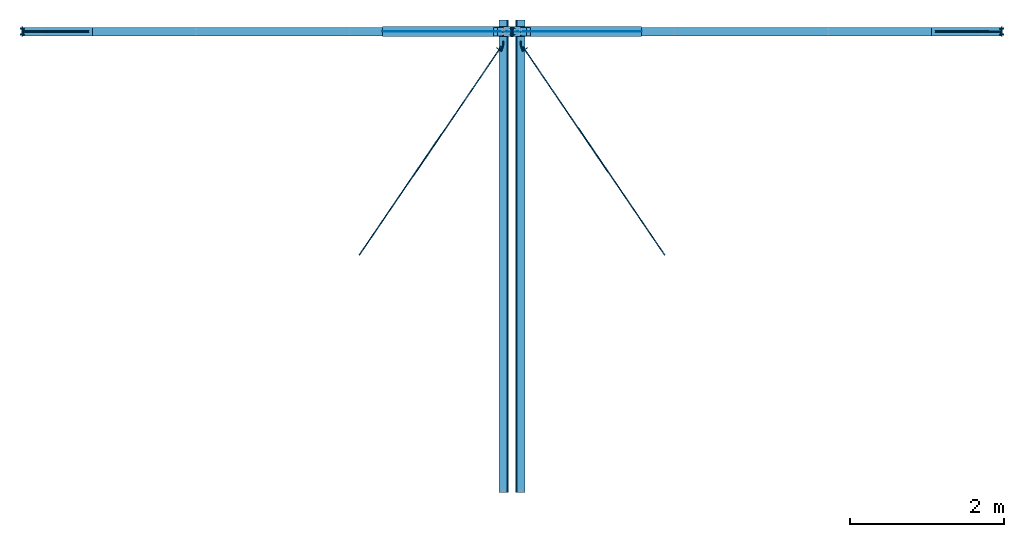
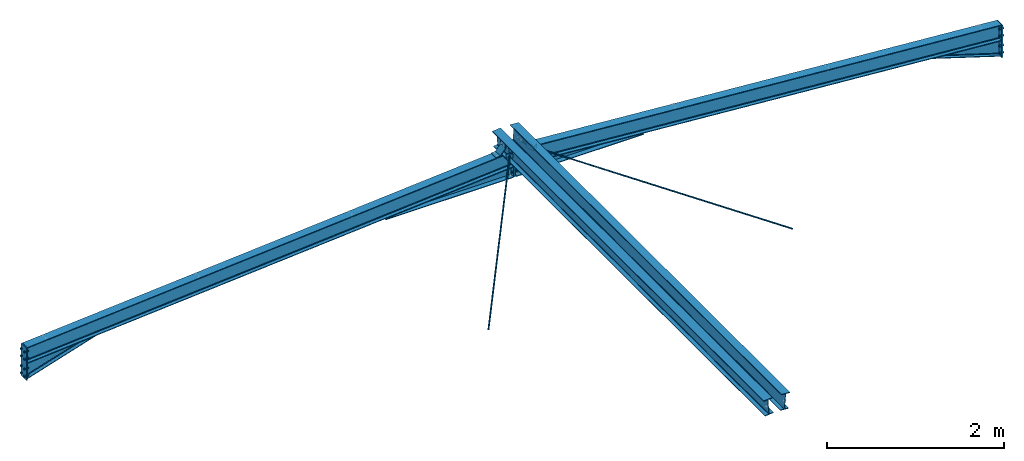
# One storey, part 1 of 3: 10 beams, 10 discrete accessories, 3 mechanical fasteners, 10 elements without a shape of their own.
"""IFC2X3 building model written with IfcOpenShell, lengths in millimetres."""

from ifc_helpers import new_model, si_unit, frame, origin_with_axes, origin_2d_with_axis, place, context, subcontext, project, spatial, polyline, circle, i_section, outline, extrude, clip, halfspace, faceted_brep, source, transform, mapped, material, type_object, element, aggregate, save


model = new_model("IFC2X3")

# Units and contexts
model_context = context("Model", 3, precision=1e-05, world=origin_with_axes())
body_context = subcontext(model_context, "Body", "Model", "MODEL_VIEW")
ifc_project = project(units=[si_unit("LENGTHUNIT", "METRE", prefix="MILLI"), si_unit("AREAUNIT", "SQUARE_METRE"), si_unit("VOLUMEUNIT", "CUBIC_METRE"), si_unit("MASSUNIT", "GRAM", prefix="KILO"), si_unit("TIMEUNIT", "SECOND"), si_unit("PLANEANGLEUNIT", "RADIAN"), si_unit("SOLIDANGLEUNIT", "STERADIAN"), si_unit("THERMODYNAMICTEMPERATUREUNIT", "DEGREE_CELSIUS"), si_unit("LUMINOUSINTENSITYUNIT", "LUMEN")], contexts=[model_context])

# Site, building, storey
site_placement = place(None, origin_with_axes())
site = spatial("IfcSite", under=ifc_project, at=site_placement, CompositionType="ELEMENT")
building_placement = place(site_placement, origin_with_axes())
building = spatial("IfcBuilding", under=site, at=building_placement, Name="Undefined", CompositionType="ELEMENT")
storey_placement = place(building_placement, origin_with_axes())
storey = spatial("IfcBuildingStorey", under=building, at=storey_placement, Name="Undefined", CompositionType="ELEMENT", Elevation=0.0)

# Assembly, beam
assembly_1_placement = place(storey_placement, origin_with_axes())
assembly_1 = element("IfcElementAssembly", 1, at=assembly_1_placement, inside=storey, Name="Steel Assembly", AssemblyPlace="NOTDEFINED", PredefinedType="RIGID_FRAME")
ifc_material_1 = material(Name="STEEL/S235JR")
beam_type_1 = type_object("IfcBeamType", PredefinedType="NOTDEFINED")
beam_1_placement = place(assembly_1_placement, frame((6257.16427529158, 24000.0, 5085.33214623635), z_axis=(0.0, 1.0, 0.0), x_axis=(0.997054485489816, 0.0, 0.0766964990376847)))
beam_1 = element("IfcBeam", 2, at=beam_1_placement, type_object=beam_type_1, material=ifc_material_1, context=body_context, shape_type="Brep", body=[
    faceted_brep([(-1.82262738235295e-09, -4.0, -55.0), (-1.82262738235295e-09, -4.0, 55.0), (1.82262738235295e-09, 4.0, 55.0), (1.82262738235295e-09, 4.0, -55.0), (59.9999997622708, 3.9999999726524, 55.0), (59.9999997622708, 3.9999999726524, -55.0), (56.6862911382423, -4.00000002583693, -55.0), (56.6862911382423, -4.00000002583693, 55.0), (139.999996300323, -76.0000007831222, 55.0), (139.999996300323, -76.0000007831222, -55.0), (131.999996203882, -79.3137090621321, -55.0), (131.999996203882, -79.3137090621321, 55.0), (139.999994554104, -135.999996851768, 55.0), (139.999994554104, -135.999996851768, -55.0), (131.999994554104, -135.999996618938, 55.0), (131.999994554104, -135.999996618938, -55.0)], [[[0, 1, 2, 3]], [[3, 2, 4, 5]], [[1, 0, 6, 7]], [[5, 4, 8, 9]], [[7, 6, 10, 11]], [[9, 8, 12, 13]], [[8, 4, 2, 1, 7, 11, 14, 12]], [[11, 10, 15, 14]], [[10, 6, 0, 3, 5, 9, 13, 15]], [[14, 15, 13, 12]]]),
])
aggregate(assembly_1, [beam_1])

assembly_2_placement = place(storey_placement, origin_with_axes())
assembly_2 = element("IfcElementAssembly", 3, at=assembly_2_placement, inside=storey, Name="Steel Assembly", AssemblyPlace="NOTDEFINED", PredefinedType="RIGID_FRAME")
beam_2_placement = place(assembly_2_placement, frame((6742.83572470515, 24000.0, 5085.33214622012), z_axis=(0.0, -1.0, 0.0), x_axis=(-0.997054485489818, 0.0, 0.0766964990376708)))
beam_2 = element("IfcBeam", 4, at=beam_2_placement, type_object=beam_type_1, material=ifc_material_1, context=body_context, shape_type="Brep", body=[
    faceted_brep([(-1.82262738235295e-09, -4.0, -55.0), (-1.82262738235295e-09, -4.0, 55.0), (1.82262738235295e-09, 4.0, 55.0), (1.82262738235295e-09, 4.0, -55.0), (59.9999997622708, 3.9999999726524, 55.0), (59.9999997622708, 3.9999999726524, -55.0), (56.6862911382423, -4.00000002583693, -55.0), (56.6862911382423, -4.00000002583693, 55.0), (139.999996300323, -76.0000007831222, 55.0), (139.999996300323, -76.0000007831222, -55.0), (131.999996203882, -79.3137090621321, -55.0), (131.999996203882, -79.3137090621321, 55.0), (139.999994554104, -135.999996851768, 55.0), (139.999994554104, -135.999996851768, -55.0), (131.999994554104, -135.999996618938, 55.0), (131.999994554104, -135.999996618938, -55.0)], [[[0, 1, 2, 3]], [[3, 2, 4, 5]], [[1, 0, 6, 7]], [[5, 4, 8, 9]], [[7, 6, 10, 11]], [[9, 8, 12, 13]], [[8, 4, 2, 1, 7, 11, 14, 12]], [[11, 10, 15, 14]], [[10, 6, 0, 3, 5, 9, 13, 15]], [[14, 15, 13, 12]]]),
])
aggregate(assembly_2, [beam_2])

assembly_3_placement = place(storey_placement, origin_with_axes())
assembly_3 = element("IfcElementAssembly", 5, at=assembly_3_placement, inside=storey, Name="Steel Assembly", AssemblyPlace="NOTDEFINED", PredefinedType="RIGID_FRAME")
beam_type_2 = type_object("IfcBeamType", Name="D14", PredefinedType="NOTDEFINED")
beam_3_placement = place(assembly_3_placement, frame((6643.29022095678, 23798.8202310421, 5199.30263958542), z_axis=(-0.0766964990376782, 0.0, -0.997054485489817), x_axis=(0.562350226933808, -0.825766911902803, -0.0432577099949082)))
beam_3 = element("IfcBeam", 6, at=beam_3_placement, type_object=beam_type_2, material=ifc_material_1, Name="THREAD60MM", ObjectType="D14", context=body_context, shape_type="SweptSolid", body=[
    extrude(circle(Radius=7.0, at=origin_2d_with_axis()), frame((3276.46854148328, -3.44046790741365e-12, -2.27350675888422e-14), z_axis=(-1.0, -6.0281640790194e-17, 6.93889390390723e-18), x_axis=(0.0, -1.0, 0.0)), (0.0, 0.0, 1.0), 3276.47),
])
aggregate(assembly_3, [beam_3])

assembly_4_placement = place(storey_placement, origin_with_axes())
assembly_4 = element("IfcElementAssembly", 7, at=assembly_4_placement, inside=storey, Name="Steel Assembly", AssemblyPlace="NOTDEFINED", PredefinedType="RIGID_FRAME")
beam_4_placement = place(assembly_4_placement, frame((6360.89585869421, 23804.9671585294, 5199.62464571418), z_axis=(0.0766964990376782, 0.0, -0.997054485489817), x_axis=(-0.562350226933808, -0.825766911902803, -0.0432577099949083)))
beam_4 = element("IfcBeam", 8, at=beam_4_placement, type_object=beam_type_2, material=ifc_material_1, Name="THREAD60MM", ObjectType="D14", context=body_context, shape_type="SweptSolid", body=[
    extrude(circle(Radius=7.0, at=origin_2d_with_axis()), frame((3283.91244290157, 3.26911877658966e-12, -9.09494701772928e-13), z_axis=(-1.0, -6.0281640790194e-17, 6.93889390390723e-18), x_axis=(0.0, -1.0, 0.0)), (0.0, 0.0, 1.0), 3283.91),
])
aggregate(assembly_4, [beam_4])

assembly_5_placement = place(storey_placement, origin_with_axes())
assembly_5 = element("IfcElementAssembly", 9, at=assembly_5_placement, inside=storey, Name="Steel Assembly", AssemblyPlace="NOTDEFINED", PredefinedType="RIGID_FRAME")
beam_type_3 = type_object("IfcBeamType", PredefinedType="NOTDEFINED")
beam_5_placement = place(assembly_5_placement, frame((6386.12943815153, 23870.8666843648, 5201.56569030629), z_axis=(-0.0766964990376782, 0.0, 0.997054485489817), x_axis=(0.0, -1.0, 0.0)))
beam_5 = element("IfcBeam", 10, at=beam_5_placement, type_object=beam_type_3, material=ifc_material_1, context=body_context, shape_type="Brep", body=[
    faceted_brep([(0.0, -2.5, -29.9999999999982), (0.0, -2.5, 30.0000000000009), (0.0, 2.50000000000182, 30.0000000000009), (0.0, 2.50000000000091, -29.9999999999982), (50.0000000000364, 2.50000000001546, 30.0), (50.0000000000364, 2.50000000001546, -29.9999999999991), (49.2179670860496, -2.49999999998545, -29.9999999999982), (49.2179670860496, -2.49999999998545, 30.0000000000009), (129.632568359368, -23.0347734445686, 30.0000000000009), (129.632568359364, -23.0347734445677, -29.9999999999991), (121.584123107255, -25.7047444547761, -29.9999999999982), (121.584123107255, -25.7047444547761, 30.0000000000009), (83.1582260131872, -88.1510930884242, 30.0), (83.1582260131909, -88.1510930884233, -30.0), (79.088455902056, -85.2464465965877, 30.0), (79.0884559020596, -85.2464465965859, -30.0)], [[[0, 1, 2, 3]], [[3, 2, 4, 5]], [[1, 0, 6, 7]], [[5, 4, 8, 9]], [[7, 6, 10, 11]], [[9, 8, 12, 13]], [[8, 4, 2, 1, 7, 11, 14, 12]], [[11, 10, 15, 14]], [[10, 6, 0, 3, 5, 9, 13, 15]], [[14, 15, 13, 12]]]),
])
aggregate(assembly_5, [beam_5])

assembly_6_placement = place(storey_placement, origin_with_axes())
assembly_6 = element("IfcElementAssembly", 11, at=assembly_6_placement, inside=storey, Name="Steel Assembly", AssemblyPlace="NOTDEFINED", PredefinedType="RIGID_FRAME")
beam_6_placement = place(assembly_6_placement, frame((6613.87056184846, 23870.8666843648, 5201.56569030629), z_axis=(0.0766964990376782, 0.0, 0.997054485489817), x_axis=(0.0, -1.0, 0.0)))
beam_6 = element("IfcBeam", 12, at=beam_6_placement, type_object=beam_type_3, material=ifc_material_1, context=body_context, shape_type="Brep", body=[
    faceted_brep([(0.0, -2.5, -29.9999999999982), (0.0, -2.5, 30.0000000000009), (0.0, 2.50000000000182, 30.0000000000009), (0.0, 2.50000000000091, -29.9999999999982), (49.2179670860496, 2.49999999998545, 30.0), (49.2179670860496, 2.49999999998636, -29.9999999999991), (50.0000000000364, -2.50000000001455, -29.9999999999991), (50.0000000000364, -2.50000000001455, 30.0), (121.584123107255, 25.704744454777, 30.0), (121.584123107255, 25.7047444547761, -29.9999999999991), (129.632568359364, 23.0347734445686, -30.0), (129.632568359368, 23.0347734445686, 30.0000000000009), (79.088455902056, 85.2464465965886, 30.0), (79.0884559020596, 85.2464465965868, -30.0000000000009), (83.1582260131872, 88.1510930884251, 30.0), (83.1582260131909, 88.1510930884242, -30.0)], [[[0, 1, 2, 3]], [[3, 2, 4, 5]], [[1, 0, 6, 7]], [[5, 4, 8, 9]], [[7, 6, 10, 11]], [[9, 8, 12, 13]], [[8, 4, 2, 1, 7, 11, 14, 12]], [[11, 10, 15, 14]], [[10, 6, 0, 3, 5, 9, 13, 15]], [[14, 15, 13, 12]]]),
])
aggregate(assembly_6, [beam_6])

assembly_7_placement = place(storey_placement, origin_with_axes())
assembly_7 = element("IfcElementAssembly", 13, at=assembly_7_placement, inside=storey, Name="Steel Assembly", AssemblyPlace="NOTDEFINED", PredefinedType="RIGID_FRAME")
beam_type_4 = type_object("IfcBeamType", Name="IPE220", PredefinedType="NOTDEFINED")
beam_7_placement = place(assembly_7_placement, frame((6608.43661485505, 18000.0, 5201.98368622292), z_axis=(0.0766964990376782, 0.0, 0.997054485489817), x_axis=(0.0, 1.0, 0.0)))
beam_7 = element("IfcBeam", 14, at=beam_7_placement, type_object=beam_type_4, material=ifc_material_1, ObjectType="IPE220", context=body_context, shape_type="Clipping", body=[
    clip(extrude(i_section(OverallWidth=110.0, OverallDepth=220.0, WebThickness=5.900000095, FlangeThickness=9.199999809, FilletRadius=12.0, at=origin_2d_with_axis()), frame((6150.0000000001, -9.09494701772928e-13, -9.09494701772928e-13), z_axis=(-1.0, -6.0281640790194e-17, 6.93889390390723e-18), x_axis=(0.0, -1.0, 0.0)), (0.0, 0.0, 1.0), 6145.0), halfspace(frame((4.99999999999272, 2.11002770811319e-10, -7.91260390542448e-11), z_axis=(1.0, 0.0, 0.0), x_axis=(0.0, -1.0, 0.0)), True)),
])
aggregate(assembly_7, [beam_7])

assembly_8_placement = place(storey_placement, origin_with_axes())
assembly_8 = element("IfcElementAssembly", 15, at=assembly_8_placement, inside=storey, Name="Steel Assembly", AssemblyPlace="NOTDEFINED", PredefinedType="RIGID_FRAME")
beam_8_placement = place(assembly_8_placement, frame((6391.56338514147, 24149.9999999999, 5201.98368623921), z_axis=(-0.0766964990376782, 0.0, 0.997054485489817), x_axis=(0.0, -1.0, 0.0)))
beam_8 = element("IfcBeam", 16, at=beam_8_placement, type_object=beam_type_4, material=ifc_material_1, ObjectType="IPE220", context=body_context, shape_type="Clipping", body=[
    clip(extrude(i_section(OverallWidth=110.0, OverallDepth=220.0, WebThickness=5.900000095, FlangeThickness=9.199999809, FilletRadius=12.0, at=origin_2d_with_axis()), frame((6144.99999999991, 9.09494701772928e-13, 0.0), z_axis=(-1.0, -6.0281640790194e-17, 6.93889390390723e-18), x_axis=(0.0, -1.0, 0.0)), (0.0, 0.0, 1.0), 6145.0), halfspace(frame((6144.99999999991, 9.09494701772928e-13, 0.0), z_axis=(1.0, 0.0, 0.0), x_axis=(0.0, -1.0, 0.0)), False)),
])
aggregate(assembly_8, [beam_8])

assembly_9_placement = place(storey_placement, origin_with_axes())
assembly_9 = element("IfcElementAssembly", 17, at=assembly_9_placement, inside=storey, Name="Steel Assembly", AssemblyPlace="NOTDEFINED", PredefinedType="RIGID_FRAME")
beam_9_placement = place(assembly_9_placement, frame((6491.56338512267, 24000.0, 4990.32400659478), z_axis=(0.0766964990376782, 0.0, 0.997054485489817), x_axis=(0.997054485489817, 0.0, -0.0766964990376815)))
beam_9 = element("IfcBeam", 18, at=beam_9_placement, type_object=beam_type_4, material=ifc_material_1, Name="POUTRE", ObjectType="IPE220", context=body_context, shape_type="Clipping", body=[
    clip(clip(extrude(i_section(OverallWidth=110.0, OverallDepth=220.0, WebThickness=5.900000095, FlangeThickness=9.199999809, FilletRadius=12.0, at=origin_2d_with_axis()), frame((6409.35743228119, 3.63797880709171e-12, 8.89477024296369e-14), z_axis=(-1.0, -6.0281640790194e-17, 6.93889390390723e-18), x_axis=(0.0, -1.0, 0.0)), (0.0, 0.0, 1.0), 6402.94), halfspace(frame((6400.72666295692, 3.63797880709171e-12, -109.999999009079), z_axis=(-0.997054485489817, 0.0, -0.0766964990376822), x_axis=(-0.0766964990376782, 0.0, 0.997054485489817)), True)), halfspace(frame((14.9558139963001, 3.63797880709171e-12, 111.150447485664), z_axis=(-0.997054485489817, 0.0, -0.0766964990376822), x_axis=(0.0, -1.0, 0.0)), False)),
])

assembly_10_placement = place(storey_placement, origin_with_axes())
assembly_10 = element("IfcElementAssembly", 19, at=assembly_10_placement, inside=storey, Name="Steel Assembly", AssemblyPlace="NOTDEFINED", PredefinedType="RIGID_FRAME")
beam_10_placement = place(assembly_10_placement, frame((8.43661487722628, 24000.0, 4490.32400659478), z_axis=(-0.0766964990376782, 0.0, 0.997054485489817), x_axis=(0.997054485489816, 0.0, 0.0766964990376847)))
beam_10 = element("IfcBeam", 20, at=beam_10_placement, type_object=beam_type_4, material=ifc_material_1, Name="POUTRE", ObjectType="IPE220", context=body_context, shape_type="Clipping", body=[
    clip(clip(extrude(i_section(OverallWidth=110.0, OverallDepth=220.0, WebThickness=5.900000095, FlangeThickness=9.199999809, FilletRadius=12.0, at=origin_2d_with_axis()), frame((6512.78885803257, 3.63797880709171e-12, 0.0), z_axis=(-1.0, -6.0281640790194e-17, 6.93889390390723e-18), x_axis=(0.0, -1.0, 0.0)), (0.0, 0.0, 1.0), 6402.94), halfspace(frame((6504.24658470657, 3.63797880709171e-12, 111.150446985645), z_axis=(-0.997054485489818, 0.0, 0.0766964990376708), x_axis=(0.0, -1.0, 0.0)), True)), halfspace(frame((118.475742245822, 3.63797880709171e-12, -110.000000009088), z_axis=(0.997054485489817, 0.0, -0.0766964990376815), x_axis=(0.0, -1.0, 0.0)), True)),
])

# Mechanical fastener
ifc_material_2 = material(Name="6.8")
discrete_accessory_type_1 = type_object("IfcDiscreteAccessoryType", Name="Bolt assembly")
shared_shape_1 = source(origin_with_axes(), body_context, "Body", "SweptSolid", [
    extrude(circle(Radius=9.0, at=origin_2d_with_axis()), frame((0.0, -14.8999999999745, 0.0), z_axis=(0.0, 1.0, 0.0), x_axis=(1.0, 0.0, 0.0)), (0.0, 0.0, 1.0), 15.0),
    extrude(circle(Radius=9.0, at=origin_2d_with_axis()), frame((0.0, -0.100000461136551, 0.0), z_axis=(0.0, 1.0, 0.0), x_axis=(1.0, 0.0, 0.0)), (0.0, 0.0, 1.0), 15.1),
    extrude(outline(polyline([(13.85640646056, 0.0), (6.92820323028, 12.0000000000017), (-6.92820323028, 12.0000000000017), (-13.85640646056, 0.0), (-6.92820323028, -12.0000000000017), (6.92820323028, -12.0000000000017), (13.85640646056, 0.0)])), frame((0.0, -24.9999999999745, 0.0), z_axis=(0.0, 1.0, 0.0), x_axis=(1.0, 0.0, 0.0)), (0.0, 0.0, 1.0), 10.0),
    extrude(circle(Radius=8.0, at=origin_2d_with_axis()), frame((0.0, -14.9999999999745, 0.0), z_axis=(0.0, 1.0, 0.0), x_axis=(1.0, 0.0, 0.0)), (0.0, 0.0, 1.0), 55.0),
    extrude(circle(Radius=12.5, at=origin_2d_with_axis()), frame((0.0, 15.0000000000255, 0.0), z_axis=(0.0, 1.0, 0.0), x_axis=(1.0, 0.0, 0.0)), (0.0, 0.0, 1.0), 4.0),
    extrude(outline(polyline([(13.85640646056, 0.0), (6.92820323028, 12.0000000000017), (-6.92820323028, 12.0000000000017), (-13.85640646056, 0.0), (-6.92820323028, -12.0000000000017), (6.92820323028, -12.0000000000017), (13.85640646056, 0.0)])), frame((0.0, 19.0000000000255, 0.0), z_axis=(0.0, 1.0, 0.0), x_axis=(1.0, 0.0, 0.0)), (0.0, 0.0, 1.0), 14.8),
])
mechanical_fastener_1_placement = place(assembly_9_placement, frame((6499.99999674043, 24000.0, 5050.0000002507), z_axis=(0.0, -1.0, 0.0), x_axis=(0.0, 0.0, -1.0)))
mechanical_fastener_1 = element("IfcMechanicalFastener", 21, at=mechanical_fastener_1_placement, type_object=discrete_accessory_type_1, material=ifc_material_2, Name="Bolt assembly", NominalDiameter=16.0, NominalLength=55.0, context=body_context, shape_type="MappedRepresentation", body=[
    mapped(shared_shape_1, transform((0.0, 0.0, -35.0))),
    mapped(shared_shape_1, transform((130.0, 0.0, -35.0))),
    mapped(shared_shape_1, transform((250.0, 0.0, -35.0))),
    mapped(shared_shape_1, transform((0.0, 0.0, 35.0))),
    mapped(shared_shape_1, transform((130.0, 0.0, 35.0))),
    mapped(shared_shape_1, transform((250.0, 0.0, 35.0))),
])

# Discrete accessory
discrete_accessory_type_2 = type_object("IfcDiscreteAccessoryType", Name="AME")
discrete_accessory_1_placement = place(assembly_9_placement, frame((6514.99999674046, 24000.0, 4814.67503646996), z_axis=(0.0, -1.0, 0.0), x_axis=(1.0, 0.0, 0.0)))
discrete_accessory_1 = element("IfcDiscreteAccessory", 22, at=discrete_accessory_1_placement, type_object=discrete_accessory_type_2, material=ifc_material_1, context=body_context, shape_type="Clipping", body=[
    clip(clip(extrude(outline(polyline([(0.0, -65.0), (0.0, 63.5211901928951), (1670.77546915619, -65.0), (0.0, -65.0)])), frame((0.0, 0.0, -3.0), z_axis=(0.0, 0.0, 1.0), x_axis=(1.0, 0.0, 0.0)), (0.0, 0.0, 1.0), 6.0), halfspace(frame((1670.77546915619, -64.9999999999991, -3.0), z_axis=(0.076696499037678, 0.997054485489817, 0.0), x_axis=(0.0, 0.0, 1.0)), False)), halfspace(frame((0.0, -65.0, -3.0), z_axis=(-1.0, -6.0281640790194e-17, 6.93889390390723e-18), x_axis=(0.0, 1.0, 0.0)), False)),
])

discrete_accessory_2_placement = place(assembly_10_placement, frame((4814.22452758438, 24000.0, 4814.67503646987), z_axis=(0.0, -1.0, 0.0), x_axis=(1.0, 0.0, 0.0)))
discrete_accessory_2 = element("IfcDiscreteAccessory", 23, at=discrete_accessory_2_placement, type_object=discrete_accessory_type_2, material=ifc_material_1, context=body_context, shape_type="Clipping", body=[
    clip(clip(extrude(outline(polyline([(1670.77546915619, -65.0), (0.0, -65.0), (1670.77546915619, 63.5211900639933), (1670.77546915619, -65.0)])), frame((0.0, 0.0, -3.0), z_axis=(0.0, 0.0, 1.0), x_axis=(1.0, 0.0, 0.0)), (0.0, 0.0, 1.0), 6.0), halfspace(frame((1670.77546915619, 63.5211900639924, -3.0), z_axis=(-0.0766964990376785, 0.997054485489817, 0.0), x_axis=(0.0, 0.0, 1.0)), False)), halfspace(frame((1670.77546915619, -65.0, 3.0), z_axis=(1.0, 0.0, 0.0), x_axis=(0.0, 1.0, 0.0)), False)),
])

discrete_accessory_type_3 = type_object("IfcDiscreteAccessoryType")
discrete_accessory_3_placement = place(assembly_9_placement, frame((6514.99999674046, 24000.0, 4744.67503646996), z_axis=(0.0, 0.0, -1.0), x_axis=(1.0, 0.0, 0.0)))
discrete_accessory_3 = element("IfcDiscreteAccessory", 24, at=discrete_accessory_3_placement, type_object=discrete_accessory_type_3, material=ifc_material_1, context=body_context, shape_type="SweptSolid", body=[
    extrude(outline(polyline([(0.0, 65.0), (1670.77546915619, 65.0), (1670.77546915619, -65.0), (0.0, -65.0), (0.0, 65.0)])), frame((0.0, 0.0, -5.0), z_axis=(0.0, 0.0, 1.0), x_axis=(1.0, 0.0, 0.0)), (0.0, 0.0, 1.0), 10.0),
])

discrete_accessory_4_placement = place(assembly_10_placement, frame((4814.22452758438, 24000.0, 4744.67503646987), z_axis=(0.0, 0.0, -1.0), x_axis=(1.0, 0.0, 0.0)))
discrete_accessory_4 = element("IfcDiscreteAccessory", 25, at=discrete_accessory_4_placement, type_object=discrete_accessory_type_3, material=ifc_material_1, context=body_context, shape_type="SweptSolid", body=[
    extrude(outline(polyline([(0.0, 65.0), (1670.77546915619, 65.0), (1670.77546915619, -65.0), (0.0, -65.0), (0.0, 65.0)])), frame((0.0, 0.0, -5.0), z_axis=(0.0, 0.0, 1.0), x_axis=(1.0, 0.0, 0.0)), (0.0, 0.0, 1.0), 10.0),
])

discrete_accessory_type_4 = type_object("IfcDiscreteAccessoryType", Name="PLAT")
discrete_accessory_5_placement = place(assembly_10_placement, frame((6492.49999674046, 24000.0, 5107.50000025078), z_axis=(-1.0, -6.0281640790194e-17, 6.93889390390723e-18), x_axis=(0.0, 0.0, -1.0)))
discrete_accessory_5 = element("IfcDiscreteAccessory", 26, at=discrete_accessory_5_placement, type_object=discrete_accessory_type_4, material=ifc_material_1, Name="PLAT", context=body_context, shape_type="SweptSolid", body=[
    extrude(outline(polyline([(359.82, 65.0), (359.82, -65.0), (0.0, -65.0), (0.0, 65.0), (359.82, 65.0)])), frame((0.0, 0.0, -7.5), z_axis=(0.0, 0.0, 1.0), x_axis=(1.0, 0.0, 0.0)), (0.0, 0.0, 1.0), 15.0),
])

discrete_accessory_6_placement = place(assembly_9_placement, frame((6507.49999674046, 24000.0, 5107.50000025078), z_axis=(-1.0, -6.0281640790194e-17, 6.93889390390723e-18), x_axis=(0.0, 0.0, -1.0)))
discrete_accessory_6 = element("IfcDiscreteAccessory", 27, at=discrete_accessory_6_placement, type_object=discrete_accessory_type_4, material=ifc_material_1, Name="PLAT", context=body_context, shape_type="SweptSolid", body=[
    extrude(outline(polyline([(359.82, 65.0), (359.82, -65.0), (0.0, -65.0), (0.0, 65.0), (359.82, 65.0)])), frame((0.0, 0.0, -7.5), z_axis=(0.0, 0.0, 1.0), x_axis=(1.0, 0.0, 0.0)), (0.0, 0.0, 1.0), 15.0),
])

# Mechanical fastener
ifc_material_3 = material(Name="HR8.8")
shared_shape_2 = source(origin_with_axes(), body_context, "Body", "SweptSolid", [
    extrude(circle(Radius=9.0, at=origin_2d_with_axis()), frame((0.0, -9.70000019100044, 0.0), z_axis=(0.0, 1.0, 0.0), x_axis=(1.0, 0.0, 0.0)), (0.0, 0.0, 1.0), 9.8),
    extrude(circle(Radius=9.0, at=origin_2d_with_axis()), frame((0.0, -0.100000461136551, 0.0), z_axis=(0.0, 1.0, 0.0), x_axis=(1.0, 0.0, 0.0)), (0.0, 0.0, 1.0), 15.1),
    extrude(outline(polyline([(15.58845726813, 0.0), (7.794228634065, 13.5000000000019), (-7.794228634065, 13.5000000000019), (-15.58845726813, 0.0), (-7.794228634065, -13.5000000000019), (7.794228634065, -13.5000000000019), (15.58845726813, 0.0)])), frame((0.0, -19.8000001910004, 0.0), z_axis=(0.0, 1.0, 0.0), x_axis=(1.0, 0.0, 0.0)), (0.0, 0.0, 1.0), 10.0),
    extrude(circle(Radius=8.0, at=origin_2d_with_axis()), frame((0.0, -9.80000019100044, 0.0), z_axis=(0.0, 1.0, 0.0), x_axis=(1.0, 0.0, 0.0)), (0.0, 0.0, 1.0), 50.0),
    extrude(circle(Radius=15.0, at=origin_2d_with_axis()), frame((0.0, 15.0000000000255, 0.0), z_axis=(0.0, 1.0, 0.0), x_axis=(1.0, 0.0, 0.0)), (0.0, 0.0, 1.0), 4.0),
    extrude(outline(polyline([(15.58845726813, 0.0), (7.794228634065, 13.5000000000019), (-7.794228634065, 13.5000000000019), (-15.58845726813, 0.0), (-7.794228634065, -13.5000000000019), (7.794228634065, -13.5000000000019), (15.58845726813, 0.0)])), frame((0.0, 19.0000000000255, 0.0), z_axis=(0.0, 1.0, 0.0), x_axis=(1.0, 0.0, 0.0)), (0.0, 0.0, 1.0), 15.0),
])
mechanical_fastener_2_placement = place(assembly_9_placement, frame((12880.0, 24000.0, 4549.23076923999), z_axis=(0.0, 1.0, 0.0), x_axis=(0.0, 0.0, -1.0)))
mechanical_fastener_2 = element("IfcMechanicalFastener", 28, at=mechanical_fastener_2_placement, type_object=discrete_accessory_type_1, material=ifc_material_3, Name="Bolt assembly", NominalDiameter=16.0, NominalLength=50.0, context=body_context, shape_type="MappedRepresentation", body=[
    mapped(shared_shape_2, transform((0.0, 0.0, -37.5))),
    mapped(shared_shape_2, transform((100.0, 0.0, -37.5))),
    mapped(shared_shape_2, transform((235.0, 0.0, -37.5))),
    mapped(shared_shape_2, transform((335.0, 0.0, -37.5))),
    mapped(shared_shape_2, transform((0.0, 0.0, 37.5))),
    mapped(shared_shape_2, transform((100.0, 0.0, 37.5))),
    mapped(shared_shape_2, transform((235.0, 0.0, 37.5))),
    mapped(shared_shape_2, transform((335.0, 0.0, 37.5))),
])

mechanical_fastener_3_placement = place(assembly_10_placement, frame((120.0, 24000.0, 4549.23076923999), z_axis=(0.0, -1.0, 0.0), x_axis=(0.0, 0.0, -1.0)))
mechanical_fastener_3 = element("IfcMechanicalFastener", 29, at=mechanical_fastener_3_placement, type_object=discrete_accessory_type_1, material=ifc_material_3, Name="Bolt assembly", NominalDiameter=16.0, NominalLength=50.0, context=body_context, shape_type="MappedRepresentation", body=[
    mapped(shared_shape_2, transform((0.0, 0.0, -37.5))),
    mapped(shared_shape_2, transform((100.0, 0.0, -37.5))),
    mapped(shared_shape_2, transform((235.0, 0.0, -37.5))),
    mapped(shared_shape_2, transform((335.0, 0.0, -37.5))),
    mapped(shared_shape_2, transform((0.0, 0.0, 37.5))),
    mapped(shared_shape_2, transform((100.0, 0.0, 37.5))),
    mapped(shared_shape_2, transform((235.0, 0.0, 37.5))),
    mapped(shared_shape_2, transform((335.0, 0.0, 37.5))),
])

# Discrete accessory
discrete_accessory_type_5 = type_object("IfcDiscreteAccessoryType")
discrete_accessory_7_placement = place(assembly_9_placement, frame((12872.5, 24000.0, 4159.2308057715), z_axis=(1.0, 0.0, 0.0), x_axis=(0.0, 0.0, 1.0)))
discrete_accessory_7 = element("IfcDiscreteAccessory", 30, at=discrete_accessory_7_placement, type_object=discrete_accessory_type_5, material=ifc_material_1, context=body_context, shape_type="SweptSolid", body=[
    extrude(outline(polyline([(0.0, 60.0), (444.999963468485, 60.0), (444.999963468485, -60.0), (0.0, -60.0), (0.0, 60.0)])), frame((0.0, 0.0, -7.5), z_axis=(0.0, 0.0, 1.0), x_axis=(1.0, 0.0, 0.0)), (0.0, 0.0, 1.0), 15.0),
])

discrete_accessory_8_placement = place(assembly_10_placement, frame((127.5, 24000.0, 4159.2308057715), z_axis=(1.0, 0.0, 0.0), x_axis=(0.0, 0.0, 1.0)))
discrete_accessory_8 = element("IfcDiscreteAccessory", 31, at=discrete_accessory_8_placement, type_object=discrete_accessory_type_5, material=ifc_material_1, context=body_context, shape_type="SweptSolid", body=[
    extrude(outline(polyline([(0.0, 60.0), (444.999963468485, 60.0), (444.999963468485, -60.0), (0.0, -60.0), (0.0, 60.0)])), frame((0.0, 0.0, -7.5), z_axis=(0.0, 0.0, 1.0), x_axis=(1.0, 0.0, 0.0)), (0.0, 0.0, 1.0), 15.0),
])

discrete_accessory_type_6 = type_object("IfcDiscreteAccessoryType")
discrete_accessory_9_placement = place(assembly_9_placement, frame((12897.9512753787, 24000.0, 4279.69160562454), z_axis=(0.299557049019384, 0.0, 0.954078390061738), x_axis=(-0.954078390061738, 0.0, 0.299557049019384)))
discrete_accessory_9 = element("IfcDiscreteAccessory", 32, at=discrete_accessory_9_placement, type_object=discrete_accessory_type_6, material=ifc_material_1, ObjectType="IPE220", context=body_context, shape_type="Clipping", body=[
    clip(clip(clip(extrude(i_section(OverallWidth=110.0, OverallDepth=220.0, WebThickness=5.900000095, FlangeThickness=9.199999809, FilletRadius=12.0, at=origin_2d_with_axis()), frame((2294.55202598923, 3.63797880709171e-12, 0.0), z_axis=(-1.0, -6.0281640790194e-17, 6.93889390390723e-18), x_axis=(0.0, -1.0, 0.0)), (0.0, 0.0, 1.0), 2774.89), halfspace(frame((-9.84148321674184, -54.9999999999964, 112.303547489119), z_axis=(0.22550022705963, 0.0, 0.974243115241804), x_axis=(0.0, 1.0, 0.0)), False)), halfspace(frame((1386.08872900273, 3.63797880709171e-12, -1253.56413263616), z_axis=(0.954078390061738, 0.0, -0.299557049019384), x_axis=(0.299557049019384, 0.0, 0.954078390061738)), False)), halfspace(frame((430.05657092133, 3.63797880709171e-12, 1259.71465761434), z_axis=(-0.954078390061738, 0.0, 0.299557049019384), x_axis=(-0.299557049019384, 0.0, -0.954078390061738)), False)),
])

aggregate(assembly_9, [mechanical_fastener_1, discrete_accessory_1, discrete_accessory_3, discrete_accessory_6, mechanical_fastener_2, discrete_accessory_7, discrete_accessory_9, beam_9])

discrete_accessory_10_placement = place(assembly_10_placement, frame((102.048724621319, 24000.0, 4279.69160562454), z_axis=(-0.299557049019384, 0.0, 0.954078390061738), x_axis=(0.954078390061738, 0.0, 0.299557049019384)))
discrete_accessory_10 = element("IfcDiscreteAccessory", 33, at=discrete_accessory_10_placement, type_object=discrete_accessory_type_6, material=ifc_material_1, ObjectType="IPE220", context=body_context, shape_type="Clipping", body=[
    clip(clip(clip(extrude(i_section(OverallWidth=110.0, OverallDepth=220.0, WebThickness=5.900000095, FlangeThickness=9.199999809, FilletRadius=12.0, at=origin_2d_with_axis()), frame((2294.55202598923, 3.63797880709171e-12, 0.0), z_axis=(-1.0, -6.0281640790194e-17, 6.93889390390723e-18), x_axis=(0.0, -1.0, 0.0)), (0.0, 0.0, 1.0), 2774.89), halfspace(frame((-9.84148321674138, 54.9999999999964, 112.303547489119), z_axis=(0.22550022705963, 0.0, 0.974243115241804), x_axis=(0.974243115241804, 0.0, -0.225500227059631)), False)), halfspace(frame((1386.08872900273, 3.63797880709171e-12, -1253.56413263616), z_axis=(0.954078390061738, 0.0, -0.299557049019384), x_axis=(0.0, -1.0, 0.0)), False)), halfspace(frame((430.05657092133, 3.63797880709171e-12, 1259.71465761434), z_axis=(-0.954078390061738, 0.0, 0.299557049019384), x_axis=(0.0, -1.0, 0.0)), False)),
])

aggregate(assembly_10, [discrete_accessory_2, discrete_accessory_4, discrete_accessory_5, mechanical_fastener_3, discrete_accessory_8, discrete_accessory_10, beam_10])

save(model, "model.ifc")
